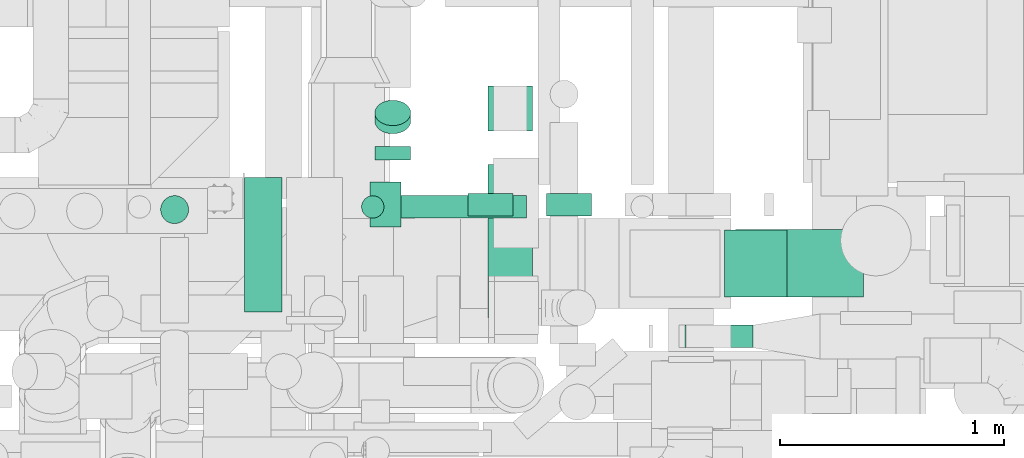
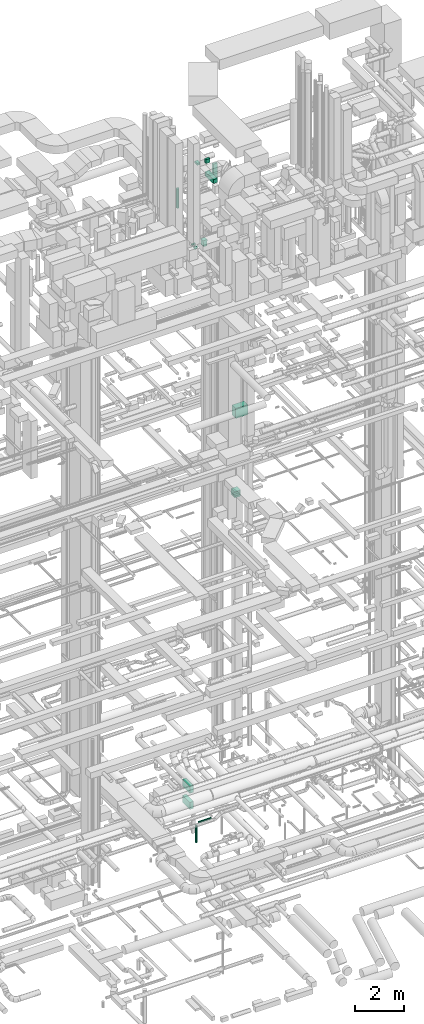
# One storey, part 195 of 337: 14 flow segments, 1 flow fitting.
"""IFC2X3 building model written with IfcOpenShell, lengths in millimetres."""

from ifc_helpers import new_model, entity, si_unit, converted_unit, derived_unit, direction, frame, origin, origin_2d_with_axis, place, context, subcontext, project, spatial, polyline, rectangle, circle, outline, extrude, source, transform, mapped, material, type_object, type_shapes, element, save


model = new_model("IFC2X3")

# Units and contexts
model_context = context("Model", 3, precision=0.01, world=origin(), true_north=direction((6.12303176911189e-17, 1.0)))
body_context = subcontext(model_context, "Body", "Model", "MODEL_VIEW")
ifc_project = project(units=[si_unit("LENGTHUNIT", "METRE", prefix="MILLI"), si_unit("AREAUNIT", "SQUARE_METRE"), si_unit("VOLUMEUNIT", "CUBIC_METRE"), converted_unit("PLANEANGLEUNIT", "DEGREE", entity("IfcRatioMeasure", 0.0174532925199433), si_unit("PLANEANGLEUNIT", "RADIAN"), dimensions=[0, 0, 0, 0, 0, 0, 0]), si_unit("MASSUNIT", "GRAM", prefix="KILO"), derived_unit("MASSDENSITYUNIT", [(si_unit("MASSUNIT", "GRAM", prefix="KILO"), 1), (si_unit("LENGTHUNIT", "METRE"), -3)]), derived_unit("MOMENTOFINERTIAUNIT", [(si_unit("LENGTHUNIT", "METRE"), 4)]), si_unit("TIMEUNIT", "SECOND"), si_unit("FREQUENCYUNIT", "HERTZ"), si_unit("THERMODYNAMICTEMPERATUREUNIT", "DEGREE_CELSIUS"), derived_unit("THERMALTRANSMITTANCEUNIT", [(si_unit("MASSUNIT", "GRAM", prefix="KILO"), 1), (si_unit("THERMODYNAMICTEMPERATUREUNIT", "KELVIN"), -1), (si_unit("TIMEUNIT", "SECOND"), -3)]), derived_unit("VOLUMETRICFLOWRATEUNIT", [(si_unit("LENGTHUNIT", "METRE"), 3), (si_unit("TIMEUNIT", "SECOND"), -1)]), derived_unit("MASSFLOWRATEUNIT", [(si_unit("MASSUNIT", "GRAM", prefix="KILO"), 1), (si_unit("TIMEUNIT", "SECOND"), -1)]), derived_unit("ROTATIONALFREQUENCYUNIT", [(si_unit("TIMEUNIT", "SECOND"), -1)]), si_unit("ELECTRICCURRENTUNIT", "AMPERE"), si_unit("ELECTRICVOLTAGEUNIT", "VOLT"), si_unit("POWERUNIT", "WATT"), si_unit("FORCEUNIT", "NEWTON", prefix="KILO"), si_unit("ILLUMINANCEUNIT", "LUX"), si_unit("LUMINOUSFLUXUNIT", "LUMEN"), si_unit("LUMINOUSINTENSITYUNIT", "CANDELA"), derived_unit("USERDEFINED", [(si_unit("MASSUNIT", "GRAM", prefix="KILO"), -1), (si_unit("LENGTHUNIT", "METRE"), -2), (si_unit("TIMEUNIT", "SECOND"), 3), (si_unit("LUMINOUSFLUXUNIT", "LUMEN"), 1)]), derived_unit("LINEARVELOCITYUNIT", [(si_unit("LENGTHUNIT", "METRE"), 1), (si_unit("TIMEUNIT", "SECOND"), -1)]), si_unit("PRESSUREUNIT", "PASCAL"), derived_unit("USERDEFINED", [(si_unit("LENGTHUNIT", "METRE"), -2), (si_unit("MASSUNIT", "GRAM", prefix="KILO"), 1), (si_unit("TIMEUNIT", "SECOND"), -2)]), derived_unit("LINEARFORCEUNIT", [(si_unit("MASSUNIT", "GRAM", prefix="KILO"), 1), (si_unit("LENGTHUNIT", "METRE"), 1), (si_unit("TIMEUNIT", "SECOND"), -2), (si_unit("LENGTHUNIT", "METRE"), -1)]), derived_unit("PLANARFORCEUNIT", [(si_unit("MASSUNIT", "GRAM", prefix="KILO"), 1), (si_unit("LENGTHUNIT", "METRE"), 1), (si_unit("TIMEUNIT", "SECOND"), -2), (si_unit("LENGTHUNIT", "METRE"), -2)])], contexts=[model_context])

# Site, building, storey
site_placement = place(None, origin())
site = spatial("IfcSite", under=ifc_project, at=site_placement, CompositionType="ELEMENT")
building_placement = place(site_placement, origin())
building = spatial("IfcBuilding", under=site, at=building_placement, CompositionType="ELEMENT")
storey_placement = place(building_placement, origin())
storey = spatial("IfcBuildingStorey", under=building, at=storey_placement, CompositionType="ELEMENT", Elevation=0.0)

# Flow segments
duct_segment_type_1 = type_object("IfcDuctSegmentType", PredefinedType="NOTDEFINED")
flow_segment_1_placement = place(storey_placement, frame((52770.21, 12642.39, 18900.0)))
element("IfcFlowSegment", 1, at=flow_segment_1_placement, inside=storey, type_object=duct_segment_type_1, context=body_context, shape_type="SweptSolid", body=[
    extrude(rectangle(XDim=569.82340330944, YDim=300.000000000001, at=origin_2d_with_axis()), frame((284.91, 150.0, 0.0), z_axis=(0.0, 0.0, 1.0), x_axis=(-1.0, 0.0, 0.0)), (0.0, 0.0, 1.0), 499.999999999999),
])
flow_segment_2_placement = place(storey_placement, frame((52720.19, 12641.61, 14975.0)))
element("IfcFlowSegment", 2, at=flow_segment_2_placement, inside=storey, type_object=duct_segment_type_1, context=body_context, shape_type="SweptSolid", body=[
    extrude(rectangle(XDim=279.999999999997, YDim=299.999999999999, at=origin_2d_with_axis()), frame((140.0, 150.0, 0.0)), (0.0, 0.0, 1.0), 300.000000000001),
])
flow_segment_3_placement = place(storey_placement, frame((52543.97, 12416.31, 15250.0)))
element("IfcFlowSegment", 3, at=flow_segment_3_placement, inside=storey, type_object=duct_segment_type_1, context=body_context, shape_type="SweptSolid", body=[
    extrude(rectangle(XDim=302.999999999948, YDim=99.9999999999989, at=origin_2d_with_axis()), frame((151.5, 50.0, 0.0), z_axis=(0.0, 0.0, 1.0), x_axis=(-1.0, 0.0, 0.0)), (0.0, 0.0, 1.0), 99.9999999999989),
])
for number, where in (
    (4, (50581.56, 12574.75, 300.06)),
    (5, (50581.56, 12574.75, 1100.06)),
):
    element("IfcFlowSegment", number, at=place(storey_placement, frame(where)), inside=storey, type_object=duct_segment_type_1, context=body_context, shape_type="SweptSolid", body=[
        extrude(rectangle(XDim=167.121828200087, YDim=600.0, at=origin_2d_with_axis()), frame((83.56, 300.0, 0.0)), (0.0, 0.0, 1.0), 350.0),
    ])
flow_segment_4_placement = place(storey_placement, frame((51666.52, 12549.6, 31000.0)))
element("IfcFlowSegment", 6, at=flow_segment_4_placement, inside=storey, type_object=duct_segment_type_1, context=body_context, shape_type="SweptSolid", body=[
    extrude(rectangle(XDim=682.987555000027, YDim=199.999999999998, at=origin_2d_with_axis()), frame((100.0, 341.49, 0.0), z_axis=(0.0, 0.0, 1.0), x_axis=(0.0, -1.0, 0.0)), (0.0, 0.0, 1.0), 199.999999999998),
])
flow_segment_5_placement = place(storey_placement, frame((51142.34, 12953.66, 31850.0)))
element("IfcFlowSegment", 7, at=flow_segment_5_placement, inside=storey, type_object=duct_segment_type_1, context=body_context, shape_type="SweptSolid", body=[
    extrude(rectangle(XDim=136.289321881408, YDim=200.0, at=origin_2d_with_axis()), frame((68.14, 100.0, 0.0)), (0.0, 0.0, 1.0), 100.000000000003),
])
flow_segment_6_placement = place(storey_placement, frame((51578.63, 13003.66, 31750.0)))
element("IfcFlowSegment", 8, at=flow_segment_6_placement, inside=storey, type_object=duct_segment_type_1, context=body_context, shape_type="SweptSolid", body=[
    extrude(rectangle(XDim=199.499999999981, YDim=100.000000000001, at=origin_2d_with_axis()), frame((99.75, 50.0, 0.0)), (0.0, 0.0, 1.0), 199.999999999998),
])
flow_segment_7_placement = place(storey_placement, frame((51928.13, 13003.66, 30740.0)))
element("IfcFlowSegment", 9, at=flow_segment_7_placement, inside=storey, type_object=duct_segment_type_1, context=body_context, shape_type="SweptSolid", body=[
    extrude(rectangle(XDim=99.9999999999989, YDim=199.999999999998, at=origin_2d_with_axis()), frame((100.0, 50.0, 0.0), z_axis=(0.0, 0.0, 1.0), x_axis=(0.0, 1.0, 0.0)), (0.0, 0.0, 1.0), 860.000000000004),
])
duct_segment_type_2 = type_object("IfcDuctSegmentType", PredefinedType="NOTDEFINED")
flow_segment_8_placement = place(storey_placement, frame((51254.01, 12991.81, -901.6)))
element("IfcFlowSegment", 10, at=flow_segment_8_placement, inside=storey, type_object=duct_segment_type_2, context=body_context, shape_type="SweptSolid", body=[
    extrude(circle(Radius=50.0, at=origin_2d_with_axis()), frame((0.0, 51.6, 51.6), z_axis=(1.0, 0.0, 0.0), x_axis=(0.0, 1.0, 0.0)), (0.0, 0.0, 1.0), 585.088376629532),
])
flow_segment_9_placement = place(storey_placement, frame((51102.41, 12991.81, -1800.0)))
element("IfcFlowSegment", 11, at=flow_segment_9_placement, inside=storey, type_object=duct_segment_type_2, context=body_context, shape_type="SweptSolid", body=[
    extrude(circle(Radius=50.0, at=origin_2d_with_axis()), frame((51.6, 51.6, 0.0), z_axis=(0.0, 0.0, 1.0), x_axis=(0.0, 1.0, 0.0)), (0.0, 0.0, 1.0), 849.999975000013),
])
flow_segment_10_placement = place(storey_placement, frame((51161.31, 13252.41, 27468.4)))
element("IfcFlowSegment", 12, at=flow_segment_10_placement, inside=storey, type_object=duct_segment_type_2, context=body_context, shape_type="SweptSolid", body=[
    extrude(circle(Radius=80.0, at=origin_2d_with_axis()), frame((81.6, 0.0, 81.6), z_axis=(0.0, 1.0, 0.0), x_axis=(1.0, 0.0, 0.0)), (0.0, 0.0, 1.0), 60.4456927448069),
])
flow_segment_11_placement = place(storey_placement, frame((50206.92, 12967.18, 30019.32)))
element("IfcFlowSegment", 13, at=flow_segment_11_placement, inside=storey, type_object=duct_segment_type_2, context=body_context, shape_type="SweptSolid", body=[
    extrude(circle(Radius=62.5, at=origin_2d_with_axis()), frame((64.1, 64.1, 0.0), z_axis=(0.0, 0.0, 1.0), x_axis=(-1.0, 0.0, 0.0)), (0.0, 0.0, 1.0), 955.677726040592),
])
flow_segment_12_placement = place(storey_placement, frame((51161.31, 13367.82, 27538.7)))
element("IfcFlowSegment", 14, at=flow_segment_12_placement, inside=storey, type_object=duct_segment_type_2, context=body_context, shape_type="SweptSolid", body=[
    extrude(circle(Radius=80.0, at=origin_2d_with_axis()), frame((81.6, 58.16, 58.16), z_axis=(0.0, 0.707106626710862, 0.707106935662199), x_axis=(1.0, 0.0, 0.0)), (0.0, 0.0, 1.0), 51.2993420344718),
])

# Flow fitting
ifc_material = material()
duct_fitting_type = type_object("IfcDuctFittingType", PredefinedType="NOTDEFINED", material=ifc_material)
shared_shape = source(origin(), body_context, "Body", "SweptSolid", [
    extrude(outline(polyline([(-143.25, -87.2), (157.79, -87.2), (141.18, 112.11), (-155.71, 62.28), (-143.25, -87.2)])), frame((150.0, 0.0, -100.0), z_axis=(0.0, 0.0, 1.0), x_axis=(0.996545758244879, -0.0830454798537418, 0.0)), (0.0, 0.0, 1.0), 200.0),
])
type_shapes(duct_fitting_type, [shared_shape])
flow_fitting_placement = place(storey_placement, frame((51766.52, 13482.59, 27360.0), z_axis=(0.0, 1.0, 0.0), x_axis=(0.0, 0.0, 1.0)))
element("IfcFlowFitting", 15, at=flow_fitting_placement, inside=storey, type_object=duct_fitting_type, material=ifc_material, context=body_context, shape_type="MappedRepresentation", body=[
    mapped(shared_shape, transform((0.0, 0.0, 0.0), scale=1.0)),
])

save(model, "model.ifc")
